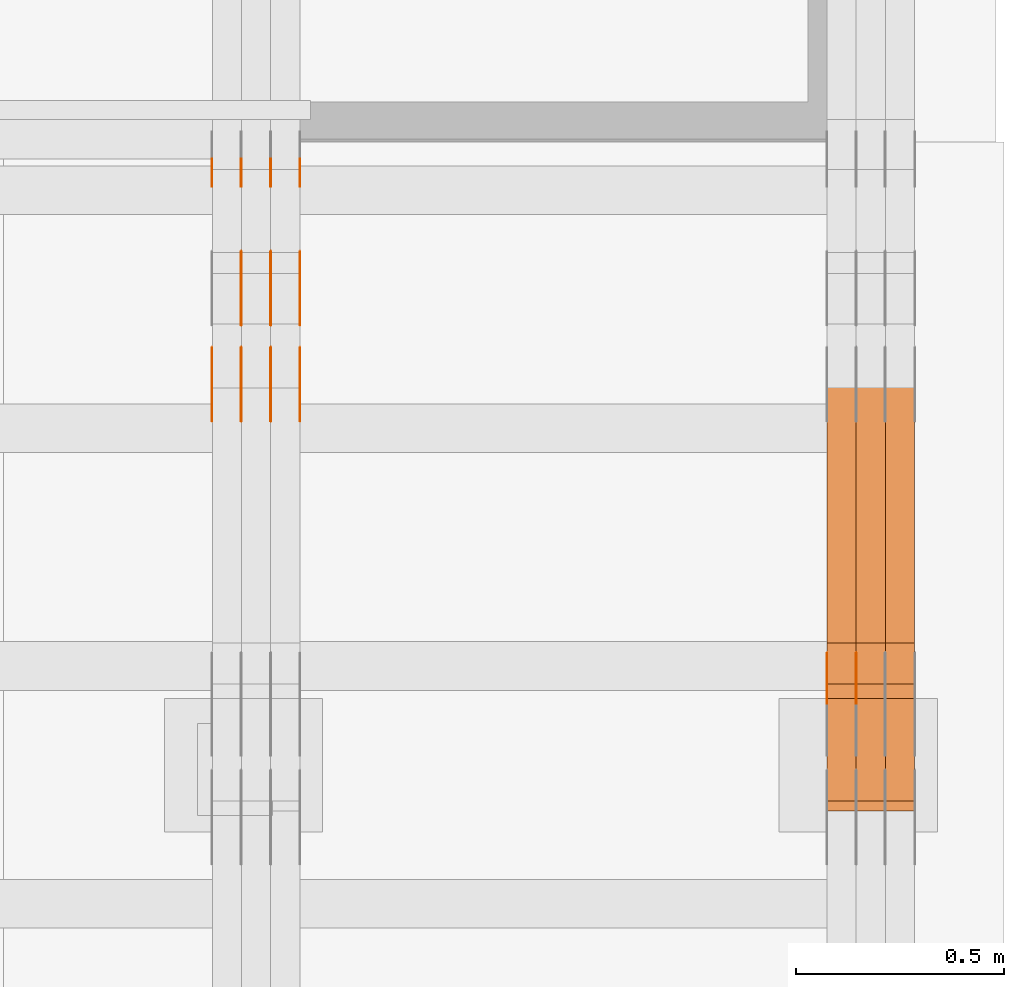
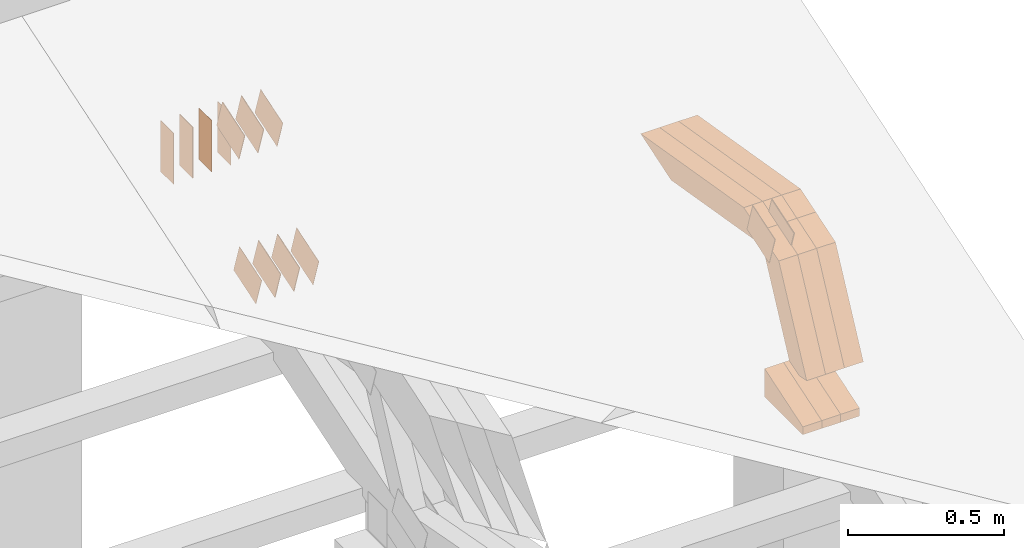
# One storey, part 322 of 385: 29 proxies.
"""IFC2X3 building model written with IfcOpenShell, lengths in millimetres."""

from ifc_helpers import new_model, entity, si_unit, converted_unit, derived_unit, direction, frame, frame_2d, origin, place, context, subcontext, project, spatial, polyline, rectangle, outline, extrude, source, transform, mapped, material, type_object, type_shapes, element, save


model = new_model("IFC2X3")

# Units and contexts
model_context = context("Model", 3, precision=0.01, world=origin(), true_north=direction((6.12303176911189e-17, 1.0)))
body_context = subcontext(model_context, "Body", "Model", "MODEL_VIEW")
ifc_project = project(units=[si_unit("LENGTHUNIT", "METRE", prefix="MILLI"), si_unit("AREAUNIT", "SQUARE_METRE"), si_unit("VOLUMEUNIT", "CUBIC_METRE"), converted_unit("PLANEANGLEUNIT", "DEGREE", entity("IfcRatioMeasure", 0.0174532925199433), si_unit("PLANEANGLEUNIT", "RADIAN"), dimensions=[0, 0, 0, 0, 0, 0, 0]), si_unit("MASSUNIT", "GRAM", prefix="KILO"), derived_unit("MASSDENSITYUNIT", [(si_unit("MASSUNIT", "GRAM", prefix="KILO"), 1), (si_unit("LENGTHUNIT", "METRE"), -3)]), si_unit("TIMEUNIT", "SECOND"), si_unit("FREQUENCYUNIT", "HERTZ"), si_unit("THERMODYNAMICTEMPERATUREUNIT", "DEGREE_CELSIUS"), derived_unit("THERMALTRANSMITTANCEUNIT", [(si_unit("MASSUNIT", "GRAM", prefix="KILO"), 1), (si_unit("THERMODYNAMICTEMPERATUREUNIT", "KELVIN"), -1), (si_unit("TIMEUNIT", "SECOND"), -3)]), derived_unit("VOLUMETRICFLOWRATEUNIT", [(si_unit("LENGTHUNIT", "METRE"), 3), (si_unit("TIMEUNIT", "SECOND"), -1)]), si_unit("ELECTRICCURRENTUNIT", "AMPERE"), si_unit("ELECTRICVOLTAGEUNIT", "VOLT"), si_unit("POWERUNIT", "WATT"), si_unit("FORCEUNIT", "NEWTON", prefix="KILO"), si_unit("ILLUMINANCEUNIT", "LUX"), si_unit("LUMINOUSFLUXUNIT", "LUMEN"), si_unit("LUMINOUSINTENSITYUNIT", "CANDELA"), derived_unit("USERDEFINED", [(si_unit("MASSUNIT", "GRAM", prefix="KILO"), -1), (si_unit("LENGTHUNIT", "METRE"), -2), (si_unit("TIMEUNIT", "SECOND"), 3), (si_unit("LUMINOUSFLUXUNIT", "LUMEN"), 1)]), derived_unit("LINEARVELOCITYUNIT", [(si_unit("LENGTHUNIT", "METRE"), 1), (si_unit("TIMEUNIT", "SECOND"), -1)]), si_unit("PRESSUREUNIT", "PASCAL"), derived_unit("USERDEFINED", [(si_unit("LENGTHUNIT", "METRE"), -2), (si_unit("MASSUNIT", "GRAM", prefix="KILO"), 1), (si_unit("TIMEUNIT", "SECOND"), -2)])], contexts=[model_context])

# Site, building, storey
site_placement = place(None, origin())
site = spatial("IfcSite", under=ifc_project, at=site_placement, CompositionType="ELEMENT")
building_placement = place(site_placement, origin())
building = spatial("IfcBuilding", under=site, at=building_placement, CompositionType="ELEMENT")
storey_placement = place(building_placement, origin())
storey = spatial("IfcBuildingStorey", under=building, at=storey_placement, Name="Default", CompositionType="ELEMENT", Elevation=0.0)

# Proxies
ifc_material_1 = material(Name="IfcSurfaceStyle #612577")
building_element_proxy_type_1 = type_object("IfcBuildingElementProxyType", PredefinedType="NOTDEFINED", material=ifc_material_1)
shared_shape_1 = source(origin(), body_context, "Body", "SweptSolid", [
    extrude(outline(polyline([(-74.9998754286244, -60.0000016373506), (74.9998605591063, -60.0000016373506), (74.9998754286244, 60.0000016373506), (-74.9998605591063, 60.0000016373506), (-74.9998754286244, -60.0000016373506)])), frame((74.9998754286244, 60.0000016373506, 0.0), z_axis=(0.0, 0.0, 1.0), x_axis=(-1.0, 0.0, 0.0)), (0.0, 0.0, 1.0), 1.29999999999999),
])
type_shapes(building_element_proxy_type_1, [shared_shape_1])
proxy_1_placement = place(building_placement, frame((49720.0, 12321.1620861463, 3506.17707344366), z_axis=(-1.0, 0.0, 0.0), x_axis=(0.0, 0.951056516295154, 0.309016994374948)))
element("IfcBuildingElementProxy", 1, at=proxy_1_placement, inside=storey, type_object=building_element_proxy_type_1, material=ifc_material_1, context=body_context, shape_type="MappedRepresentation", body=[
    mapped(shared_shape_1, transform((0.0, 0.0, 0.0), scale=1.0)),
])
ifc_material_2 = material(Name="IfcSurfaceStyle #612520")
building_element_proxy_type_2 = type_object("IfcBuildingElementProxyType", PredefinedType="NOTDEFINED", material=ifc_material_2)
shared_shape_2 = source(origin(), body_context, "Body", "SweptSolid", [
    extrude(outline(polyline([(-74.9998754286244, -60.0000016373506), (74.9998605591063, -60.0000016373506), (74.9998754286244, 60.0000016373506), (-74.9998605591063, 60.0000016373506), (-74.9998754286244, -60.0000016373506)])), frame((74.9998754286244, 60.0000016373506, 0.0), z_axis=(0.0, 0.0, 1.0), x_axis=(-1.0, 0.0, 0.0)), (0.0, 0.0, 1.0), 1.29999999999999),
])
type_shapes(building_element_proxy_type_2, [shared_shape_2])
proxy_2_placement = place(building_placement, frame((49721.3, 12321.1620861463, 3506.17707344366), z_axis=(-1.0, 0.0, 0.0), x_axis=(0.0, 0.951056516295154, 0.309016994374948)))
element("IfcBuildingElementProxy", 2, at=proxy_2_placement, inside=storey, type_object=building_element_proxy_type_2, material=ifc_material_2, context=body_context, shape_type="MappedRepresentation", body=[
    mapped(shared_shape_2, transform((0.0, 0.0, 0.0), scale=1.0)),
])
ifc_material_3 = material(Name="IfcSurfaceStyle #612463")
building_element_proxy_type_3 = type_object("IfcBuildingElementProxyType", PredefinedType="NOTDEFINED", material=ifc_material_3)
shared_shape_3 = source(origin(), body_context, "Body", "SweptSolid", [
    extrude(outline(polyline([(-74.9998754286244, -60.0000016373506), (74.9998605591063, -60.0000016373506), (74.9998754286244, 60.0000016373506), (-74.9998605591063, 60.0000016373506), (-74.9998754286244, -60.0000016373506)])), frame((74.9998754286244, 60.0000016373506, 0.0), z_axis=(0.0, 0.0, 1.0), x_axis=(-1.0, 0.0, 0.0)), (0.0, 0.0, 1.0), 1.29999999999999),
])
type_shapes(building_element_proxy_type_3, [shared_shape_3])
proxy_3_placement = place(building_placement, frame((49650.0, 12321.1620861463, 3506.17707344366), z_axis=(-1.0, 0.0, 0.0), x_axis=(0.0, 0.951056516295154, 0.309016994374948)))
element("IfcBuildingElementProxy", 3, at=proxy_3_placement, inside=storey, type_object=building_element_proxy_type_3, material=ifc_material_3, context=body_context, shape_type="MappedRepresentation", body=[
    mapped(shared_shape_3, transform((0.0, 0.0, 0.0), scale=1.0)),
])
ifc_material_4 = material(Name="IfcSurfaceStyle #604288")
building_element_proxy_type_4 = type_object("IfcBuildingElementProxyType", Name="T2-E1 604286", PredefinedType="NOTDEFINED", material=ifc_material_4)
shared_shape_4 = source(origin(), body_context, "Body", "SweptSolid", [
    extrude(outline(polyline([(-75.1378173828004, -122.500000000005), (35.3350830078246, -122.500000000005), (35.3350830078004, 122.500000000005), (4.46765136717545, 122.500000000005), (-75.1378173828004, -122.500000000005)])), frame((35.3350830078246, 122.500000104877, 0.0), z_axis=(0.0, 0.0, 1.0), x_axis=(-1.0, 0.0, 0.0)), (0.0, 0.0, 1.0), 70.0),
])
type_shapes(building_element_proxy_type_4, [shared_shape_4])
proxy_4_placement = place(building_placement, frame((49860.0, 12145.0, 2849.54565429685), z_axis=(-1.0, 0.0, 0.0), x_axis=(0.0, 0.0, 1.0)))
element("IfcBuildingElementProxy", 4, at=proxy_4_placement, inside=storey, type_object=building_element_proxy_type_4, material=ifc_material_4, Name="T2-E1", context=body_context, shape_type="MappedRepresentation", body=[
    mapped(shared_shape_4, transform((0.0, 0.0, 0.0), scale=1.0)),
])
ifc_material_5 = material(Name="IfcSurfaceStyle #604231")
building_element_proxy_type_5 = type_object("IfcBuildingElementProxyType", Name="T2-E1 604229", PredefinedType="NOTDEFINED", material=ifc_material_5)
shared_shape_5 = source(origin(), body_context, "Body", "SweptSolid", [
    extrude(outline(polyline([(-75.1378173828004, -122.500000000005), (35.3350830078246, -122.500000000005), (35.3350830078004, 122.500000000005), (4.46765136717545, 122.500000000005), (-75.1378173828004, -122.500000000005)])), frame((35.3350830078246, 122.500000104877, 0.0), z_axis=(0.0, 0.0, 1.0), x_axis=(-1.0, 0.0, 0.0)), (0.0, 0.0, 1.0), 70.0),
])
type_shapes(building_element_proxy_type_5, [shared_shape_5])
proxy_5_placement = place(building_placement, frame((49790.0, 12145.0, 2849.54565429685), z_axis=(-1.0, 0.0, 0.0), x_axis=(0.0, 0.0, 1.0)))
element("IfcBuildingElementProxy", 5, at=proxy_5_placement, inside=storey, type_object=building_element_proxy_type_5, material=ifc_material_5, Name="T2-E1", context=body_context, shape_type="MappedRepresentation", body=[
    mapped(shared_shape_5, transform((0.0, 0.0, 0.0), scale=1.0)),
])
ifc_material_6 = material(Name="IfcSurfaceStyle #604174")
building_element_proxy_type_6 = type_object("IfcBuildingElementProxyType", Name="T2-E1 604172", PredefinedType="NOTDEFINED", material=ifc_material_6)
shared_shape_6 = source(origin(), body_context, "Body", "SweptSolid", [
    extrude(outline(polyline([(-75.1378173828004, -122.500000000005), (35.3350830078246, -122.500000000005), (35.3350830078004, 122.500000000005), (4.46765136717545, 122.500000000005), (-75.1378173828004, -122.500000000005)])), frame((35.3350830078246, 122.500000104877, 0.0), z_axis=(0.0, 0.0, 1.0), x_axis=(-1.0, 0.0, 0.0)), (0.0, 0.0, 1.0), 70.0),
])
type_shapes(building_element_proxy_type_6, [shared_shape_6])
proxy_6_placement = place(building_placement, frame((49720.0, 12145.0, 2849.54565429685), z_axis=(-1.0, 0.0, 0.0), x_axis=(0.0, 0.0, 1.0)))
element("IfcBuildingElementProxy", 6, at=proxy_6_placement, inside=storey, type_object=building_element_proxy_type_6, material=ifc_material_6, Name="T2-E1", context=body_context, shape_type="MappedRepresentation", body=[
    mapped(shared_shape_6, transform((0.0, 0.0, 0.0), scale=1.0)),
])
ifc_material_7 = material(Name="IfcSurfaceStyle #602560")
building_element_proxy_type_7 = type_object("IfcBuildingElementProxyType", Name="T2-W7 602558", PredefinedType="NOTDEFINED", material=ifc_material_7)
shared_shape_7 = source(origin(), body_context, "Body", "SweptSolid", [
    extrude(outline(polyline([(-296.174043820986, -47.5000676566704), (297.841254477443, -47.5000676566704), (283.518570346415, -7.10254316533821e-06), (192.674144473719, 47.500071207942), (-477.859925476591, 47.500071207942), (-296.174043820986, -47.5000676566704)])), frame((297.841254477443, 47.5000816097442, 0.0), z_axis=(0.0, 0.0, 1.0), x_axis=(-1.0, 0.0, 0.0)), (0.0, 0.0, 1.0), 70.0),
])
type_shapes(building_element_proxy_type_7, [shared_shape_7])
proxy_7_placement = place(building_placement, frame((49860.0, 12419.2991208897, 3526.2136755972), z_axis=(-1.0, 0.0, 0.0), x_axis=(0.0, 0.985983815111804, -0.166840991178939)))
element("IfcBuildingElementProxy", 7, at=proxy_7_placement, inside=storey, type_object=building_element_proxy_type_7, material=ifc_material_7, Name="T2-W7", context=body_context, shape_type="MappedRepresentation", body=[
    mapped(shared_shape_7, transform((0.0, 0.0, 0.0), scale=1.0)),
])
ifc_material_8 = material(Name="IfcSurfaceStyle #602494")
building_element_proxy_type_8 = type_object("IfcBuildingElementProxyType", Name="T2-W7 602492", PredefinedType="NOTDEFINED", material=ifc_material_8)
shared_shape_8 = source(origin(), body_context, "Body", "SweptSolid", [
    extrude(outline(polyline([(-296.174043820986, -47.5000676566704), (297.841254477443, -47.5000676566704), (283.518570346415, -7.10254316533821e-06), (192.674144473719, 47.500071207942), (-477.859925476591, 47.500071207942), (-296.174043820986, -47.5000676566704)])), frame((297.841254477443, 47.5000816097442, 0.0), z_axis=(0.0, 0.0, 1.0), x_axis=(-1.0, 0.0, 0.0)), (0.0, 0.0, 1.0), 70.0),
])
type_shapes(building_element_proxy_type_8, [shared_shape_8])
proxy_8_placement = place(building_placement, frame((49790.0, 12419.2991208897, 3526.2136755972), z_axis=(-1.0, 0.0, 0.0), x_axis=(0.0, 0.985983815111804, -0.166840991178939)))
element("IfcBuildingElementProxy", 8, at=proxy_8_placement, inside=storey, type_object=building_element_proxy_type_8, material=ifc_material_8, Name="T2-W7", context=body_context, shape_type="MappedRepresentation", body=[
    mapped(shared_shape_8, transform((0.0, 0.0, 0.0), scale=1.0)),
])
ifc_material_9 = material(Name="IfcSurfaceStyle #602428")
building_element_proxy_type_9 = type_object("IfcBuildingElementProxyType", Name="T2-W7 602426", PredefinedType="NOTDEFINED", material=ifc_material_9)
shared_shape_9 = source(origin(), body_context, "Body", "SweptSolid", [
    extrude(outline(polyline([(-296.174043820986, -47.5000676566704), (297.841254477443, -47.5000676566704), (283.518570346415, -7.10254316533821e-06), (192.674144473719, 47.500071207942), (-477.859925476591, 47.500071207942), (-296.174043820986, -47.5000676566704)])), frame((297.841254477443, 47.5000816097442, 0.0), z_axis=(0.0, 0.0, 1.0), x_axis=(-1.0, 0.0, 0.0)), (0.0, 0.0, 1.0), 70.0),
])
type_shapes(building_element_proxy_type_9, [shared_shape_9])
proxy_9_placement = place(building_placement, frame((49720.0, 12419.2991208897, 3526.2136755972), z_axis=(-1.0, 0.0, 0.0), x_axis=(0.0, 0.985983815111804, -0.166840991178939)))
element("IfcBuildingElementProxy", 9, at=proxy_9_placement, inside=storey, type_object=building_element_proxy_type_9, material=ifc_material_9, Name="T2-W7", context=body_context, shape_type="MappedRepresentation", body=[
    mapped(shared_shape_9, transform((0.0, 0.0, 0.0), scale=1.0)),
])
ifc_material_10 = material(Name="IfcSurfaceStyle #602164")
building_element_proxy_type_10 = type_object("IfcBuildingElementProxyType", Name="T2-W36 602162", PredefinedType="NOTDEFINED", material=ifc_material_10)
shared_shape_10 = source(origin(), body_context, "Body", "SweptSolid", [
    extrude(outline(polyline([(-300.714670922549, -47.4998881108849), (134.031527004269, -47.499888110885), (180.52054953879, -0.000136170977331764), (193.89900152221, 47.500563476126), (-207.736407142719, 47.4993489166213), (-300.714670922549, -47.4998881108849)])), frame((193.899145164686, 47.5001861375837, 0.0), z_axis=(0.0, 0.0, 1.0), x_axis=(-1.0, 3.02403492980632e-06, 0.0)), (0.0, 0.0, 1.0), 70.0),
])
type_shapes(building_element_proxy_type_10, [shared_shape_10])
proxy_10_placement = place(building_placement, frame((49860.0, 12120.5935627532, 3076.1128858536), z_axis=(-1.0, 0.0, 0.0), x_axis=(0.0, 0.444384650266842, 0.895836080210669)))
element("IfcBuildingElementProxy", 10, at=proxy_10_placement, inside=storey, type_object=building_element_proxy_type_10, material=ifc_material_10, Name="T2-W36", context=body_context, shape_type="MappedRepresentation", body=[
    mapped(shared_shape_10, transform((0.0, 0.0, 0.0), scale=1.0)),
])
ifc_material_11 = material(Name="IfcSurfaceStyle #602098")
building_element_proxy_type_11 = type_object("IfcBuildingElementProxyType", Name="T2-W36 602096", PredefinedType="NOTDEFINED", material=ifc_material_11)
shared_shape_11 = source(origin(), body_context, "Body", "SweptSolid", [
    extrude(outline(polyline([(-300.714670922549, -47.4998881108849), (134.031527004269, -47.499888110885), (180.52054953879, -0.000136170977331764), (193.89900152221, 47.500563476126), (-207.736407142719, 47.4993489166213), (-300.714670922549, -47.4998881108849)])), frame((193.899145164686, 47.5001861375837, 0.0), z_axis=(0.0, 0.0, 1.0), x_axis=(-1.0, 3.02403492980632e-06, 0.0)), (0.0, 0.0, 1.0), 70.0),
])
type_shapes(building_element_proxy_type_11, [shared_shape_11])
proxy_11_placement = place(building_placement, frame((49790.0, 12120.5935627532, 3076.1128858536), z_axis=(-1.0, 0.0, 0.0), x_axis=(0.0, 0.444384650266842, 0.895836080210669)))
element("IfcBuildingElementProxy", 11, at=proxy_11_placement, inside=storey, type_object=building_element_proxy_type_11, material=ifc_material_11, Name="T2-W36", context=body_context, shape_type="MappedRepresentation", body=[
    mapped(shared_shape_11, transform((0.0, 0.0, 0.0), scale=1.0)),
])
ifc_material_12 = material(Name="IfcSurfaceStyle #602032")
building_element_proxy_type_12 = type_object("IfcBuildingElementProxyType", Name="T2-W36 602030", PredefinedType="NOTDEFINED", material=ifc_material_12)
shared_shape_12 = source(origin(), body_context, "Body", "SweptSolid", [
    extrude(outline(polyline([(-300.714670922549, -47.4998881108849), (134.031527004269, -47.499888110885), (180.52054953879, -0.000136170977331764), (193.89900152221, 47.500563476126), (-207.736407142719, 47.4993489166213), (-300.714670922549, -47.4998881108849)])), frame((193.899145164686, 47.5001861375837, 0.0), z_axis=(0.0, 0.0, 1.0), x_axis=(-1.0, 3.02403492980632e-06, 0.0)), (0.0, 0.0, 1.0), 70.0),
])
type_shapes(building_element_proxy_type_12, [shared_shape_12])
proxy_12_placement = place(building_placement, frame((49720.0, 12120.5935627532, 3076.1128858536), z_axis=(-1.0, 0.0, 0.0), x_axis=(0.0, 0.444384650266842, 0.895836080210669)))
element("IfcBuildingElementProxy", 12, at=proxy_12_placement, inside=storey, type_object=building_element_proxy_type_12, material=ifc_material_12, Name="T2-W36", context=body_context, shape_type="MappedRepresentation", body=[
    mapped(shared_shape_12, transform((0.0, 0.0, 0.0), scale=1.0)),
])
ifc_material_13 = material(Name="IfcSurfaceStyle #587892")
building_element_proxy_type_13 = type_object("IfcBuildingElementProxyType", PredefinedType="NOTDEFINED", material=ifc_material_13)
shared_shape_13 = source(origin(), body_context, "Body", "SweptSolid", [
    extrude(rectangle(XDim=200.0, YDim=84.0, at=frame_2d((0.0, -7.105427357601e-15), x_axis=(1.0, 0.0))), frame((100.0, 42.0, 0.0), z_axis=(0.0, 0.0, 1.0), x_axis=(-1.0, 0.0, 0.0)), (0.0, 0.0, 1.0), 1.3),
])
type_shapes(building_element_proxy_type_13, [shared_shape_13])
proxy_13_placement = place(building_placement, frame((48386.3, 13702.0, 3651.4150390625), z_axis=(-1.0, 0.0, 0.0), x_axis=(0.0, 0.0, -1.0)))
element("IfcBuildingElementProxy", 13, at=proxy_13_placement, inside=storey, type_object=building_element_proxy_type_13, material=ifc_material_13, context=body_context, shape_type="MappedRepresentation", body=[
    mapped(shared_shape_13, transform((0.0, 0.0, 0.0), scale=1.0)),
])
ifc_material_14 = material(Name="IfcSurfaceStyle #587835")
building_element_proxy_type_14 = type_object("IfcBuildingElementProxyType", PredefinedType="NOTDEFINED", material=ifc_material_14)
shared_shape_14 = source(origin(), body_context, "Body", "SweptSolid", [
    extrude(rectangle(XDim=200.0, YDim=84.0, at=frame_2d((0.0, -7.105427357601e-15), x_axis=(1.0, 0.0))), frame((100.0, 42.0, 0.0), z_axis=(0.0, 0.0, 1.0), x_axis=(-1.0, 0.0, 0.0)), (0.0, 0.0, 1.0), 1.3),
])
type_shapes(building_element_proxy_type_14, [shared_shape_14])
proxy_14_placement = place(building_placement, frame((48315.0, 13702.0, 3651.4150390625), z_axis=(-1.0, 0.0, 0.0), x_axis=(0.0, 0.0, -1.0)))
element("IfcBuildingElementProxy", 14, at=proxy_14_placement, inside=storey, type_object=building_element_proxy_type_14, material=ifc_material_14, context=body_context, shape_type="MappedRepresentation", body=[
    mapped(shared_shape_14, transform((0.0, 0.0, 0.0), scale=1.0)),
])
ifc_material_15 = material(Name="IfcSurfaceStyle #587778")
building_element_proxy_type_15 = type_object("IfcBuildingElementProxyType", PredefinedType="NOTDEFINED", material=ifc_material_15)
shared_shape_15 = source(origin(), body_context, "Body", "SweptSolid", [
    extrude(rectangle(XDim=200.0, YDim=84.0, at=frame_2d((0.0, -7.105427357601e-15), x_axis=(1.0, 0.0))), frame((100.0, 42.0, 0.0), z_axis=(0.0, 0.0, 1.0), x_axis=(-1.0, 0.0, 0.0)), (0.0, 0.0, 1.0), 1.3),
])
type_shapes(building_element_proxy_type_15, [shared_shape_15])
proxy_15_placement = place(building_placement, frame((48316.3, 13702.0, 3651.4150390625), z_axis=(-1.0, 0.0, 0.0), x_axis=(0.0, 0.0, -1.0)))
element("IfcBuildingElementProxy", 15, at=proxy_15_placement, inside=storey, type_object=building_element_proxy_type_15, material=ifc_material_15, context=body_context, shape_type="MappedRepresentation", body=[
    mapped(shared_shape_15, transform((0.0, 0.0, 0.0), scale=1.0)),
])
ifc_material_16 = material(Name="IfcSurfaceStyle #587721")
building_element_proxy_type_16 = type_object("IfcBuildingElementProxyType", PredefinedType="NOTDEFINED", material=ifc_material_16)
shared_shape_16 = source(origin(), body_context, "Body", "SweptSolid", [
    extrude(rectangle(XDim=200.0, YDim=84.0, at=frame_2d((0.0, -7.105427357601e-15), x_axis=(1.0, 0.0))), frame((100.0, 42.0, 0.0), z_axis=(0.0, 0.0, 1.0), x_axis=(-1.0, 0.0, 0.0)), (0.0, 0.0, 1.0), 1.29999999999998),
])
type_shapes(building_element_proxy_type_16, [shared_shape_16])
proxy_16_placement = place(building_placement, frame((48245.0, 13702.0, 3651.4150390625), z_axis=(-1.0, 0.0, 0.0), x_axis=(0.0, 0.0, -1.0)))
element("IfcBuildingElementProxy", 16, at=proxy_16_placement, inside=storey, type_object=building_element_proxy_type_16, material=ifc_material_16, context=body_context, shape_type="MappedRepresentation", body=[
    mapped(shared_shape_16, transform((0.0, 0.0, 0.0), scale=1.0)),
])
ifc_material_17 = material(Name="IfcSurfaceStyle #587664")
building_element_proxy_type_17 = type_object("IfcBuildingElementProxyType", PredefinedType="NOTDEFINED", material=ifc_material_17)
shared_shape_17 = source(origin(), body_context, "Body", "SweptSolid", [
    extrude(rectangle(XDim=200.0, YDim=84.0, at=frame_2d((0.0, -7.105427357601e-15), x_axis=(1.0, 0.0))), frame((100.0, 42.0, 0.0), z_axis=(0.0, 0.0, 1.0), x_axis=(-1.0, 0.0, 0.0)), (0.0, 0.0, 1.0), 1.29999999999998),
])
type_shapes(building_element_proxy_type_17, [shared_shape_17])
proxy_17_placement = place(building_placement, frame((48246.3, 13702.0, 3651.4150390625), z_axis=(-1.0, 0.0, 0.0), x_axis=(0.0, 0.0, -1.0)))
element("IfcBuildingElementProxy", 17, at=proxy_17_placement, inside=storey, type_object=building_element_proxy_type_17, material=ifc_material_17, context=body_context, shape_type="MappedRepresentation", body=[
    mapped(shared_shape_17, transform((0.0, 0.0, 0.0), scale=1.0)),
])
ifc_material_18 = material(Name="IfcSurfaceStyle #587607")
building_element_proxy_type_18 = type_object("IfcBuildingElementProxyType", PredefinedType="NOTDEFINED", material=ifc_material_18)
shared_shape_18 = source(origin(), body_context, "Body", "SweptSolid", [
    extrude(rectangle(XDim=200.0, YDim=84.0, at=frame_2d((0.0, -7.105427357601e-15), x_axis=(1.0, 0.0))), frame((100.0, 42.0, 0.0), z_axis=(0.0, 0.0, 1.0), x_axis=(-1.0, 0.0, 0.0)), (0.0, 0.0, 1.0), 1.29999999999999),
])
type_shapes(building_element_proxy_type_18, [shared_shape_18])
proxy_18_placement = place(building_placement, frame((48175.0, 13702.0, 3651.4150390625), z_axis=(-1.0, 0.0, 0.0), x_axis=(0.0, 0.0, -1.0)))
element("IfcBuildingElementProxy", 18, at=proxy_18_placement, inside=storey, type_object=building_element_proxy_type_18, material=ifc_material_18, context=body_context, shape_type="MappedRepresentation", body=[
    mapped(shared_shape_18, transform((0.0, 0.0, 0.0), scale=1.0)),
])
ifc_material_19 = material(Name="IfcSurfaceStyle #587550")
building_element_proxy_type_19 = type_object("IfcBuildingElementProxyType", PredefinedType="NOTDEFINED", material=ifc_material_19)
shared_shape_19 = source(origin(), body_context, "Body", "SweptSolid", [
    extrude(outline(polyline([(-75.0003398116828, -59.9998507501386), (75.0003249421766, -59.9998507501386), (75.0003398116837, 59.9998507501387), (-75.0003249421775, 59.9998507501387), (-75.0003398116828, -59.9998507501386)])), frame((75.0003398116837, 60.0000773549637, 0.0), z_axis=(0.0, 0.0, 1.0), x_axis=(-1.0, 0.0, 0.0)), (0.0, 0.0, 1.0), 1.3),
])
type_shapes(building_element_proxy_type_19, [shared_shape_19])
proxy_19_placement = place(building_placement, frame((48386.3, 13054.73046875, 3417.8388671875), z_axis=(-1.0, 0.0, 0.0), x_axis=(0.0, 0.951056516295124, 0.309016994375039)))
element("IfcBuildingElementProxy", 19, at=proxy_19_placement, inside=storey, type_object=building_element_proxy_type_19, material=ifc_material_19, context=body_context, shape_type="MappedRepresentation", body=[
    mapped(shared_shape_19, transform((0.0, 0.0, 0.0), scale=1.0)),
])
ifc_material_20 = material(Name="IfcSurfaceStyle #587493")
building_element_proxy_type_20 = type_object("IfcBuildingElementProxyType", PredefinedType="NOTDEFINED", material=ifc_material_20)
shared_shape_20 = source(origin(), body_context, "Body", "SweptSolid", [
    extrude(outline(polyline([(-75.0003398116828, -59.9998507501386), (75.0003249421766, -59.9998507501386), (75.0003398116837, 59.9998507501387), (-75.0003249421775, 59.9998507501387), (-75.0003398116828, -59.9998507501386)])), frame((75.0003398116837, 60.0000773549637, 0.0), z_axis=(0.0, 0.0, 1.0), x_axis=(-1.0, 0.0, 0.0)), (0.0, 0.0, 1.0), 1.3),
])
type_shapes(building_element_proxy_type_20, [shared_shape_20])
proxy_20_placement = place(building_placement, frame((48315.0, 13054.73046875, 3417.8388671875), z_axis=(-1.0, 0.0, 0.0), x_axis=(0.0, 0.951056516295124, 0.309016994375039)))
element("IfcBuildingElementProxy", 20, at=proxy_20_placement, inside=storey, type_object=building_element_proxy_type_20, material=ifc_material_20, context=body_context, shape_type="MappedRepresentation", body=[
    mapped(shared_shape_20, transform((0.0, 0.0, 0.0), scale=1.0)),
])
ifc_material_21 = material(Name="IfcSurfaceStyle #587436")
building_element_proxy_type_21 = type_object("IfcBuildingElementProxyType", PredefinedType="NOTDEFINED", material=ifc_material_21)
shared_shape_21 = source(origin(), body_context, "Body", "SweptSolid", [
    extrude(outline(polyline([(-75.0003398116828, -59.9998507501386), (75.0003249421766, -59.9998507501386), (75.0003398116837, 59.9998507501387), (-75.0003249421775, 59.9998507501387), (-75.0003398116828, -59.9998507501386)])), frame((75.0003398116837, 60.0000773549637, 0.0), z_axis=(0.0, 0.0, 1.0), x_axis=(-1.0, 0.0, 0.0)), (0.0, 0.0, 1.0), 1.3),
])
type_shapes(building_element_proxy_type_21, [shared_shape_21])
proxy_21_placement = place(building_placement, frame((48316.3, 13054.73046875, 3417.8388671875), z_axis=(-1.0, 0.0, 0.0), x_axis=(0.0, 0.951056516295124, 0.309016994375039)))
element("IfcBuildingElementProxy", 21, at=proxy_21_placement, inside=storey, type_object=building_element_proxy_type_21, material=ifc_material_21, context=body_context, shape_type="MappedRepresentation", body=[
    mapped(shared_shape_21, transform((0.0, 0.0, 0.0), scale=1.0)),
])
ifc_material_22 = material(Name="IfcSurfaceStyle #587379")
building_element_proxy_type_22 = type_object("IfcBuildingElementProxyType", PredefinedType="NOTDEFINED", material=ifc_material_22)
shared_shape_22 = source(origin(), body_context, "Body", "SweptSolid", [
    extrude(outline(polyline([(-75.0003398116828, -59.9998507501386), (75.0003249421766, -59.9998507501386), (75.0003398116837, 59.9998507501387), (-75.0003249421775, 59.9998507501387), (-75.0003398116828, -59.9998507501386)])), frame((75.0003398116837, 60.0000773549637, 0.0), z_axis=(0.0, 0.0, 1.0), x_axis=(-1.0, 0.0, 0.0)), (0.0, 0.0, 1.0), 1.29999999999999),
])
type_shapes(building_element_proxy_type_22, [shared_shape_22])
proxy_22_placement = place(building_placement, frame((48245.0, 13054.73046875, 3417.8388671875), z_axis=(-1.0, 0.0, 0.0), x_axis=(0.0, 0.951056516295124, 0.309016994375039)))
element("IfcBuildingElementProxy", 22, at=proxy_22_placement, inside=storey, type_object=building_element_proxy_type_22, material=ifc_material_22, context=body_context, shape_type="MappedRepresentation", body=[
    mapped(shared_shape_22, transform((0.0, 0.0, 0.0), scale=1.0)),
])
ifc_material_23 = material(Name="IfcSurfaceStyle #587322")
building_element_proxy_type_23 = type_object("IfcBuildingElementProxyType", PredefinedType="NOTDEFINED", material=ifc_material_23)
shared_shape_23 = source(origin(), body_context, "Body", "SweptSolid", [
    extrude(outline(polyline([(-75.0003398116828, -59.9998507501386), (75.0003249421766, -59.9998507501386), (75.0003398116837, 59.9998507501387), (-75.0003249421775, 59.9998507501387), (-75.0003398116828, -59.9998507501386)])), frame((75.0003398116837, 60.0000773549637, 0.0), z_axis=(0.0, 0.0, 1.0), x_axis=(-1.0, 0.0, 0.0)), (0.0, 0.0, 1.0), 1.29999999999999),
])
type_shapes(building_element_proxy_type_23, [shared_shape_23])
proxy_23_placement = place(building_placement, frame((48246.3, 13054.73046875, 3417.8388671875), z_axis=(-1.0, 0.0, 0.0), x_axis=(0.0, 0.951056516295124, 0.309016994375039)))
element("IfcBuildingElementProxy", 23, at=proxy_23_placement, inside=storey, type_object=building_element_proxy_type_23, material=ifc_material_23, context=body_context, shape_type="MappedRepresentation", body=[
    mapped(shared_shape_23, transform((0.0, 0.0, 0.0), scale=1.0)),
])
ifc_material_24 = material(Name="IfcSurfaceStyle #587265")
building_element_proxy_type_24 = type_object("IfcBuildingElementProxyType", PredefinedType="NOTDEFINED", material=ifc_material_24)
shared_shape_24 = source(origin(), body_context, "Body", "SweptSolid", [
    extrude(outline(polyline([(-75.0003398116828, -59.9998507501386), (75.0003249421766, -59.9998507501386), (75.0003398116837, 59.9998507501387), (-75.0003249421775, 59.9998507501387), (-75.0003398116828, -59.9998507501386)])), frame((75.0003398116837, 60.0000773549637, 0.0), z_axis=(0.0, 0.0, 1.0), x_axis=(-1.0, 0.0, 0.0)), (0.0, 0.0, 1.0), 1.29999999999999),
])
type_shapes(building_element_proxy_type_24, [shared_shape_24])
proxy_24_placement = place(building_placement, frame((48175.0, 13054.73046875, 3417.8388671875), z_axis=(-1.0, 0.0, 0.0), x_axis=(0.0, 0.951056516295124, 0.309016994375039)))
element("IfcBuildingElementProxy", 24, at=proxy_24_placement, inside=storey, type_object=building_element_proxy_type_24, material=ifc_material_24, context=body_context, shape_type="MappedRepresentation", body=[
    mapped(shared_shape_24, transform((0.0, 0.0, 0.0), scale=1.0)),
])
ifc_material_25 = material(Name="IfcSurfaceStyle #579684")
building_element_proxy_type_25 = type_object("IfcBuildingElementProxyType", PredefinedType="NOTDEFINED", material=ifc_material_25)
shared_shape_25 = source(origin(), body_context, "Body", "SweptSolid", [
    extrude(outline(polyline([(-74.999875428623, -60.0000016373506), (74.9998605591059, -60.0000016373506), (74.9998754286239, 60.0000016373506), (-74.9998605591068, 60.0000016373506), (-74.999875428623, -60.0000016373506)])), frame((75.0002691827262, 60.0000190504561, 0.0), z_axis=(0.0, 0.0, 1.0), x_axis=(-1.0, 0.0, 0.0)), (0.0, 0.0, 1.0), 1.3),
])
type_shapes(building_element_proxy_type_25, [shared_shape_25])
proxy_25_placement = place(building_placement, frame((48386.3, 13285.0865109705, 3819.37496637467), z_axis=(-1.0, 0.0, 0.0), x_axis=(0.0, 0.951056516295154, 0.309016994374948)))
element("IfcBuildingElementProxy", 25, at=proxy_25_placement, inside=storey, type_object=building_element_proxy_type_25, material=ifc_material_25, context=body_context, shape_type="MappedRepresentation", body=[
    mapped(shared_shape_25, transform((0.0, 0.0, 0.0), scale=1.0)),
])
ifc_material_26 = material(Name="IfcSurfaceStyle #579627")
building_element_proxy_type_26 = type_object("IfcBuildingElementProxyType", PredefinedType="NOTDEFINED", material=ifc_material_26)
shared_shape_26 = source(origin(), body_context, "Body", "SweptSolid", [
    extrude(outline(polyline([(-74.999875428623, -60.0000016373506), (74.9998605591059, -60.0000016373506), (74.9998754286239, 60.0000016373506), (-74.9998605591068, 60.0000016373506), (-74.999875428623, -60.0000016373506)])), frame((75.0002691827262, 60.0000190504561, 0.0), z_axis=(0.0, 0.0, 1.0), x_axis=(-1.0, 0.0, 0.0)), (0.0, 0.0, 1.0), 1.3),
])
type_shapes(building_element_proxy_type_26, [shared_shape_26])
proxy_26_placement = place(building_placement, frame((48315.0, 13285.0865109705, 3819.37496637467), z_axis=(-1.0, 0.0, 0.0), x_axis=(0.0, 0.951056516295154, 0.309016994374948)))
element("IfcBuildingElementProxy", 26, at=proxy_26_placement, inside=storey, type_object=building_element_proxy_type_26, material=ifc_material_26, context=body_context, shape_type="MappedRepresentation", body=[
    mapped(shared_shape_26, transform((0.0, 0.0, 0.0), scale=1.0)),
])
ifc_material_27 = material(Name="IfcSurfaceStyle #579570")
building_element_proxy_type_27 = type_object("IfcBuildingElementProxyType", PredefinedType="NOTDEFINED", material=ifc_material_27)
shared_shape_27 = source(origin(), body_context, "Body", "SweptSolid", [
    extrude(outline(polyline([(-74.999875428623, -60.0000016373506), (74.9998605591059, -60.0000016373506), (74.9998754286239, 60.0000016373506), (-74.9998605591068, 60.0000016373506), (-74.999875428623, -60.0000016373506)])), frame((75.0002691827262, 60.0000190504561, 0.0), z_axis=(0.0, 0.0, 1.0), x_axis=(-1.0, 0.0, 0.0)), (0.0, 0.0, 1.0), 1.3),
])
type_shapes(building_element_proxy_type_27, [shared_shape_27])
proxy_27_placement = place(building_placement, frame((48316.3, 13285.0865109705, 3819.37496637467), z_axis=(-1.0, 0.0, 0.0), x_axis=(0.0, 0.951056516295154, 0.309016994374948)))
element("IfcBuildingElementProxy", 27, at=proxy_27_placement, inside=storey, type_object=building_element_proxy_type_27, material=ifc_material_27, context=body_context, shape_type="MappedRepresentation", body=[
    mapped(shared_shape_27, transform((0.0, 0.0, 0.0), scale=1.0)),
])
ifc_material_28 = material(Name="IfcSurfaceStyle #579513")
building_element_proxy_type_28 = type_object("IfcBuildingElementProxyType", PredefinedType="NOTDEFINED", material=ifc_material_28)
shared_shape_28 = source(origin(), body_context, "Body", "SweptSolid", [
    extrude(outline(polyline([(-74.999875428623, -60.0000016373506), (74.9998605591059, -60.0000016373506), (74.9998754286239, 60.0000016373506), (-74.9998605591068, 60.0000016373506), (-74.999875428623, -60.0000016373506)])), frame((75.0002691827262, 60.0000190504561, 0.0), z_axis=(0.0, 0.0, 1.0), x_axis=(-1.0, 0.0, 0.0)), (0.0, 0.0, 1.0), 1.29999999999999),
])
type_shapes(building_element_proxy_type_28, [shared_shape_28])
proxy_28_placement = place(building_placement, frame((48245.0, 13285.0865109705, 3819.37496637467), z_axis=(-1.0, 0.0, 0.0), x_axis=(0.0, 0.951056516295154, 0.309016994374948)))
element("IfcBuildingElementProxy", 28, at=proxy_28_placement, inside=storey, type_object=building_element_proxy_type_28, material=ifc_material_28, context=body_context, shape_type="MappedRepresentation", body=[
    mapped(shared_shape_28, transform((0.0, 0.0, 0.0), scale=1.0)),
])
ifc_material_29 = material(Name="IfcSurfaceStyle #579456")
building_element_proxy_type_29 = type_object("IfcBuildingElementProxyType", PredefinedType="NOTDEFINED", material=ifc_material_29)
shared_shape_29 = source(origin(), body_context, "Body", "SweptSolid", [
    extrude(outline(polyline([(-74.999875428623, -60.0000016373506), (74.9998605591059, -60.0000016373506), (74.9998754286239, 60.0000016373506), (-74.9998605591068, 60.0000016373506), (-74.999875428623, -60.0000016373506)])), frame((75.0002691827262, 60.0000190504561, 0.0), z_axis=(0.0, 0.0, 1.0), x_axis=(-1.0, 0.0, 0.0)), (0.0, 0.0, 1.0), 1.29999999999999),
])
type_shapes(building_element_proxy_type_29, [shared_shape_29])
proxy_29_placement = place(building_placement, frame((48246.3, 13285.0865109705, 3819.37496637467), z_axis=(-1.0, 0.0, 0.0), x_axis=(0.0, 0.951056516295154, 0.309016994374948)))
element("IfcBuildingElementProxy", 29, at=proxy_29_placement, inside=storey, type_object=building_element_proxy_type_29, material=ifc_material_29, context=body_context, shape_type="MappedRepresentation", body=[
    mapped(shared_shape_29, transform((0.0, 0.0, 0.0), scale=1.0)),
])

save(model, "model.ifc")
